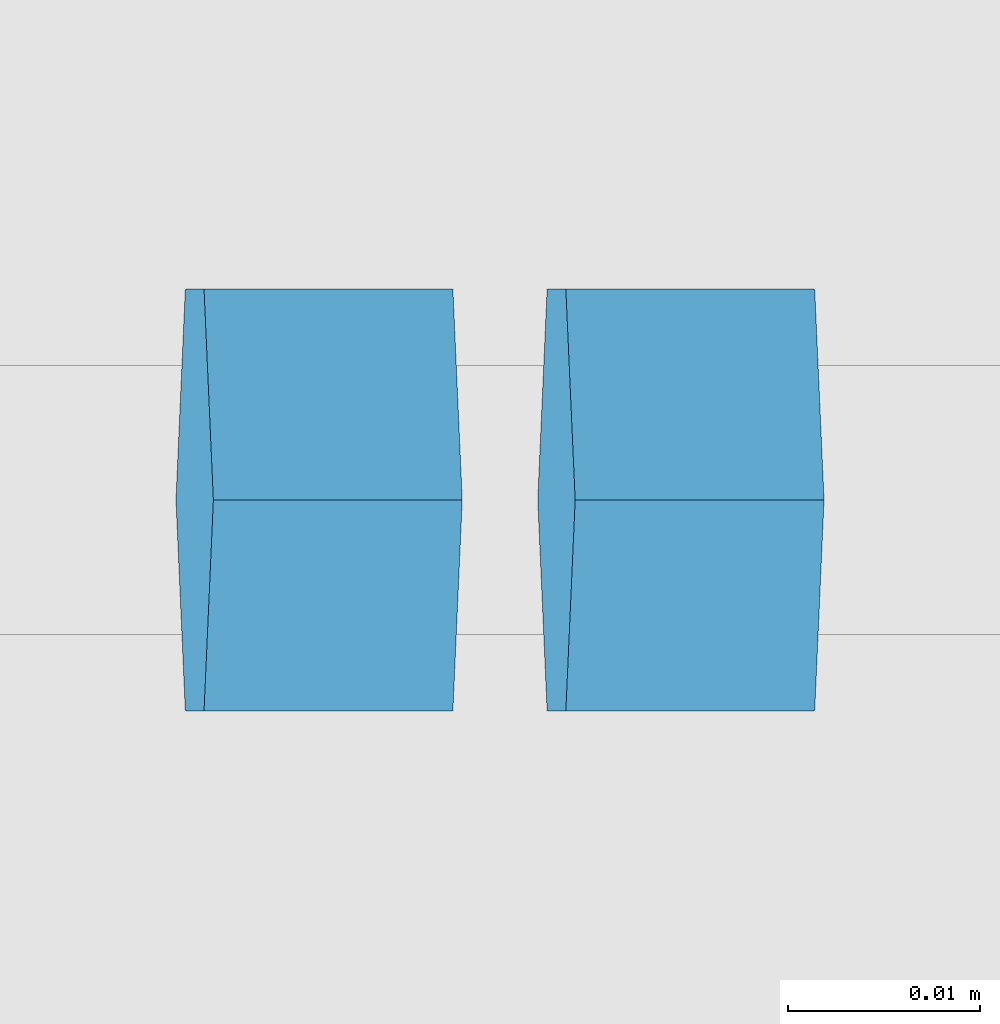
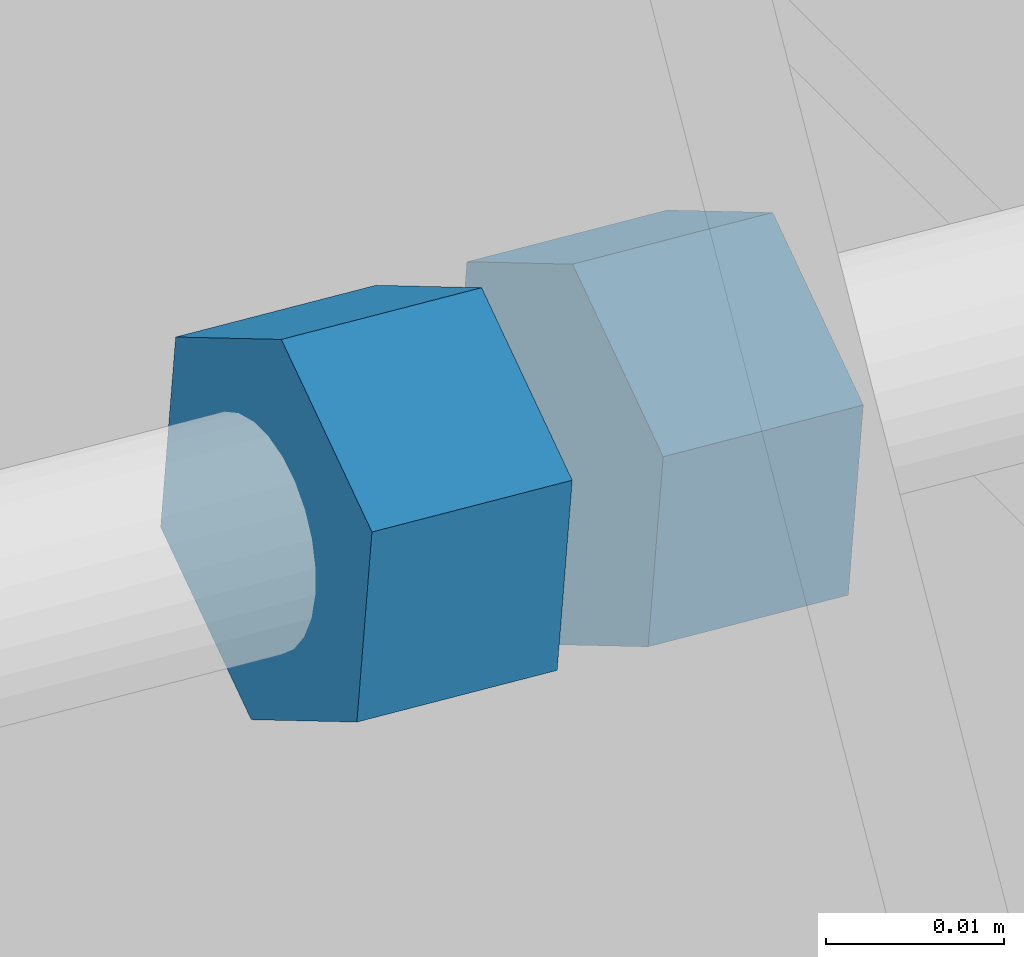
# One storey, part 34 of 70: 2 beams, 2 elements without a shape of their own.
"""IFC2X3 building model written with IfcOpenShell, lengths in millimetres."""

from ifc_helpers import new_model, si_unit, frame, origin_with_axes, place, context, subcontext, project, spatial, polyline, outline, extrude, material, type_object, element, aggregate, save


model = new_model("IFC2X3")

# Units and contexts
model_context = context("Model", 3, precision=1e-05, world=origin_with_axes())
body_context = subcontext(model_context, "Body", "Model", "MODEL_VIEW")
ifc_project = project(units=[si_unit("LENGTHUNIT", "METRE", prefix="MILLI"), si_unit("AREAUNIT", "SQUARE_METRE"), si_unit("VOLUMEUNIT", "CUBIC_METRE"), si_unit("MASSUNIT", "GRAM", prefix="KILO"), si_unit("TIMEUNIT", "SECOND"), si_unit("PLANEANGLEUNIT", "RADIAN"), si_unit("SOLIDANGLEUNIT", "STERADIAN"), si_unit("THERMODYNAMICTEMPERATUREUNIT", "DEGREE_CELSIUS"), si_unit("LUMINOUSINTENSITYUNIT", "LUMEN")], contexts=[model_context])

# Site, building, storey
site_placement = place(None, origin_with_axes())
site = spatial("IfcSite", under=ifc_project, at=site_placement, CompositionType="ELEMENT")
building_placement = place(site_placement, origin_with_axes())
building = spatial("IfcBuilding", under=site, at=building_placement, Name="Undefined", CompositionType="ELEMENT")
storey_placement = place(building_placement, origin_with_axes())
storey = spatial("IfcBuildingStorey", under=building, at=storey_placement, Name="Undefined", CompositionType="ELEMENT", Elevation=0.0)

# Assembly, beam
assembly_1_placement = place(storey_placement, origin_with_axes())
assembly_1 = element("IfcElementAssembly", 1, at=assembly_1_placement, inside=storey, Name="Steel Assembly", AssemblyPlace="NOTDEFINED", PredefinedType="RIGID_FRAME")
ifc_material = material(Name="STEEL/S235JR")
beam_type = type_object("IfcBeamType", Name="M14", PredefinedType="NOTDEFINED")
beam_1_placement = place(assembly_1_placement, frame((12505.4953042319, 21060.0000000184, 4748.36378773468), z_axis=(0.0, 1.0, 0.0), x_axis=(-0.997054485489817, 0.0, 0.0766964990376713)))
beam_1 = element("IfcBeam", 2, at=beam_1_placement, type_object=beam_type, material=ifc_material, Name="M14", ObjectType="M14", context=body_context, shape_type="SweptSolid", body=[
    extrude(outline(polyline([(12.7045926734972, 1.09139364212751e-11), (6.35229633673589, -11.002499999985), (-6.352296336775, -11.0024999999832), (-12.7045926735282, 1.36424205265939e-11), (-6.35229633676863, 11.0025000000087), (6.35229633674408, 11.0025000000069), (12.7045926734972, 1.09139364212751e-11)])), frame((13.0000000000422, -9.09404496152177e-13, 4.28476698567782e-16), z_axis=(-1.0, 0.0, 0.0), x_axis=(0.0, -1.0, 0.0)), (0.0, 0.0, 1.0), 13.0),
])
aggregate(assembly_1, [beam_1])

assembly_2_placement = place(storey_placement, origin_with_axes())
assembly_2 = element("IfcElementAssembly", 3, at=assembly_2_placement, inside=storey, Name="Steel Assembly", AssemblyPlace="NOTDEFINED", PredefinedType="RIGID_FRAME")
beam_2_placement = place(assembly_2_placement, frame((12511.377925791, 21060.0000000184, 4747.91127838276), z_axis=(0.0, -1.0, 0.0), x_axis=(0.997054485489817, 0.0, -0.0766964990376783)))
beam_2 = element("IfcBeam", 4, at=beam_2_placement, type_object=beam_type, material=ifc_material, Name="M14", ObjectType="M14", context=body_context, shape_type="SweptSolid", body=[
    extrude(outline(polyline([(12.7045926734972, 1.09139364212751e-11), (6.35229633673589, -11.002499999985), (-6.352296336775, -11.0024999999832), (-12.7045926735282, 1.36424205265939e-11), (-6.35229633676863, 11.0025000000087), (6.35229633674408, 11.0025000000069), (12.7045926734972, 1.09139364212751e-11)])), frame((13.0000000000422, -9.09404496152177e-13, 4.28476698567782e-16), z_axis=(-1.0, 0.0, 0.0), x_axis=(0.0, -1.0, 0.0)), (0.0, 0.0, 1.0), 13.0),
])
aggregate(assembly_2, [beam_2])

save(model, "model.ifc")
